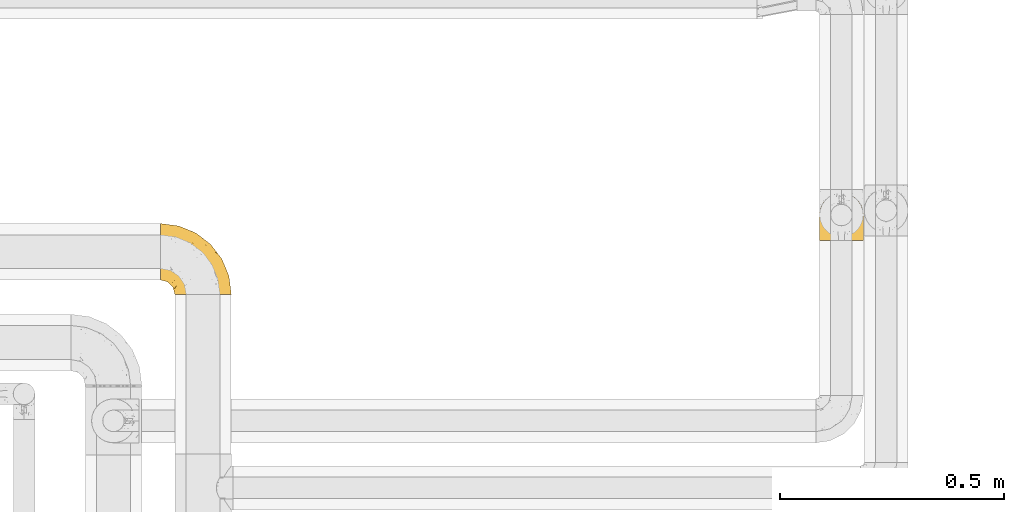
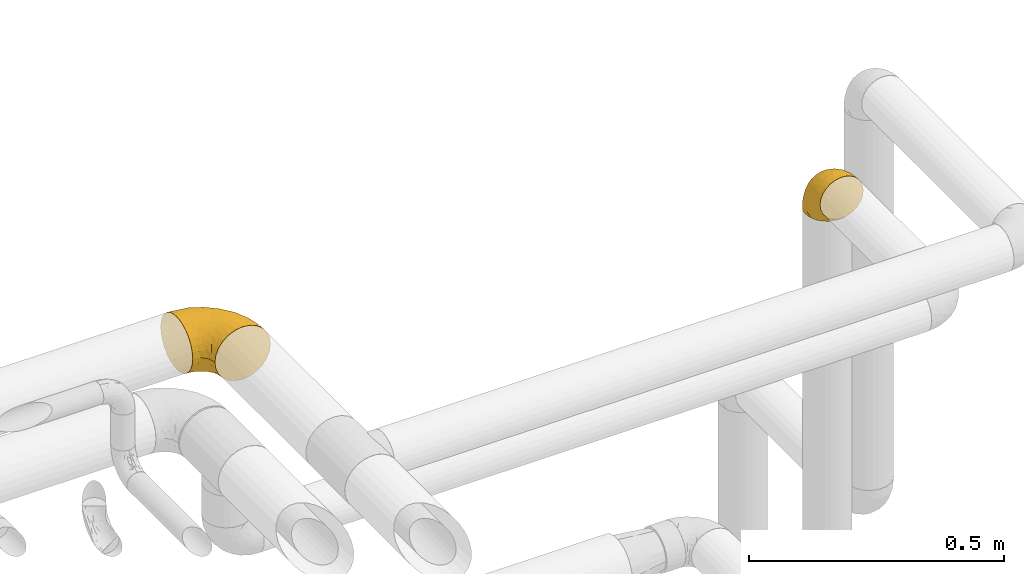
# One storey, part 414 of 827: 2 coverings.
"""IFC2X3 building model written with IfcOpenShell, lengths in millimetres."""

from ifc_helpers import new_model, entity, si_unit, converted_unit, derived_unit, direction, frame, origin, place, context, subcontext, project, spatial, faceted_brep, element, save


model = new_model("IFC2X3")

# Units and contexts
model_context = context("Model", 3, precision=0.01, world=origin(), true_north=direction((6.12303176911189e-17, 1.0)))
body_context = subcontext(model_context, "Body", "Model", "MODEL_VIEW")
ifc_project = project(units=[si_unit("LENGTHUNIT", "METRE", prefix="MILLI"), si_unit("AREAUNIT", "SQUARE_METRE"), si_unit("VOLUMEUNIT", "CUBIC_METRE"), converted_unit("PLANEANGLEUNIT", "DEGREE", entity("IfcRatioMeasure", 0.0174532925199433), si_unit("PLANEANGLEUNIT", "RADIAN"), dimensions=[0, 0, 0, 0, 0, 0, 0]), si_unit("MASSUNIT", "GRAM", prefix="KILO"), derived_unit("MASSDENSITYUNIT", [(si_unit("MASSUNIT", "GRAM", prefix="KILO"), 1), (si_unit("LENGTHUNIT", "METRE"), -3)]), derived_unit("MOMENTOFINERTIAUNIT", [(si_unit("LENGTHUNIT", "METRE"), 4)]), si_unit("TIMEUNIT", "SECOND"), si_unit("FREQUENCYUNIT", "HERTZ"), si_unit("THERMODYNAMICTEMPERATUREUNIT", "DEGREE_CELSIUS"), derived_unit("THERMALTRANSMITTANCEUNIT", [(si_unit("MASSUNIT", "GRAM", prefix="KILO"), 1), (si_unit("THERMODYNAMICTEMPERATUREUNIT", "KELVIN"), -1), (si_unit("TIMEUNIT", "SECOND"), -3)]), derived_unit("VOLUMETRICFLOWRATEUNIT", [(si_unit("LENGTHUNIT", "METRE"), 3), (si_unit("TIMEUNIT", "SECOND"), -1)]), derived_unit("MASSFLOWRATEUNIT", [(si_unit("MASSUNIT", "GRAM", prefix="KILO"), 1), (si_unit("TIMEUNIT", "SECOND"), -1)]), derived_unit("ROTATIONALFREQUENCYUNIT", [(si_unit("TIMEUNIT", "SECOND"), -1)]), si_unit("ELECTRICCURRENTUNIT", "AMPERE"), si_unit("ELECTRICVOLTAGEUNIT", "VOLT"), si_unit("POWERUNIT", "WATT"), si_unit("FORCEUNIT", "NEWTON", prefix="KILO"), si_unit("ILLUMINANCEUNIT", "LUX"), si_unit("LUMINOUSFLUXUNIT", "LUMEN"), si_unit("LUMINOUSINTENSITYUNIT", "CANDELA"), derived_unit("USERDEFINED", [(si_unit("MASSUNIT", "GRAM", prefix="KILO"), -1), (si_unit("LENGTHUNIT", "METRE"), -2), (si_unit("TIMEUNIT", "SECOND"), 3), (si_unit("LUMINOUSFLUXUNIT", "LUMEN"), 1)]), derived_unit("LINEARVELOCITYUNIT", [(si_unit("LENGTHUNIT", "METRE"), 1), (si_unit("TIMEUNIT", "SECOND"), -1)]), si_unit("PRESSUREUNIT", "PASCAL"), derived_unit("USERDEFINED", [(si_unit("LENGTHUNIT", "METRE"), -2), (si_unit("MASSUNIT", "GRAM", prefix="KILO"), 1), (si_unit("TIMEUNIT", "SECOND"), -2)]), derived_unit("LINEARFORCEUNIT", [(si_unit("MASSUNIT", "GRAM", prefix="KILO"), 1), (si_unit("LENGTHUNIT", "METRE"), 1), (si_unit("TIMEUNIT", "SECOND"), -2), (si_unit("LENGTHUNIT", "METRE"), -1)]), derived_unit("PLANARFORCEUNIT", [(si_unit("MASSUNIT", "GRAM", prefix="KILO"), 1), (si_unit("LENGTHUNIT", "METRE"), 1), (si_unit("TIMEUNIT", "SECOND"), -2), (si_unit("LENGTHUNIT", "METRE"), -2)])], contexts=[model_context])

# Site, building, storey
site_placement = place(None, origin())
site = spatial("IfcSite", under=ifc_project, at=site_placement, CompositionType="ELEMENT")
building_placement = place(site_placement, origin())
building = spatial("IfcBuilding", under=site, at=building_placement, CompositionType="ELEMENT")
storey_placement = place(building_placement, frame((0.0, 0.0, 28200.0)))
storey = spatial("IfcBuildingStorey", under=building, at=storey_placement, Name="08", CompositionType="ELEMENT", Elevation=28200.0)

# Coverings
covering_1_placement = place(storey_placement, frame((48748.44, 18461.91, 2935.35)))
element("IfcCovering", 1, at=covering_1_placement, inside=storey, Name=":ADSK_", ObjectType=":ADSK_", PredefinedType="INSULATION", context=body_context, shape_type="Brep", body=[
    faceted_brep([(1.6, 110.62, 126.11), (1.6, 123.95, 121.45), (1.6, 135.9, 113.94), (1.6, 145.89, 103.96), (1.6, 153.4, 92.0), (1.6, 158.06, 78.68), (1.6, 159.65, 64.65), (1.6, 158.06, 50.62), (1.6, 153.4, 37.29), (1.6, 145.89, 25.34), (1.6, 135.91, 15.35), (1.6, 123.95, 7.84), (1.6, 110.63, 3.18), (1.6, 96.6, 1.6), (1.6, 82.57, 3.18), (1.6, 69.24, 7.84), (1.6, 57.29, 15.35), (1.6, 47.3, 25.33), (1.6, 39.79, 37.29), (1.6, 35.13, 50.61), (1.6, 33.55, 64.65), (1.6, 35.13, 78.67), (1.6, 39.79, 92.0), (1.6, 47.3, 103.95), (1.6, 57.28, 113.94), (1.6, 69.24, 121.45), (1.6, 82.56, 126.11), (1.6, 96.6, 127.7), (33.55, 1.6, 64.65), (35.69, 1.6, 48.33), (41.99, 1.6, 33.12), (52.01, 1.6, 20.06), (65.07, 1.6, 10.04), (80.28, 1.6, 3.74), (85.89, 1.6, 3.01), (96.6, 1.6, 1.6), (112.91, 1.6, 3.74), (128.12, 1.6, 10.04), (141.18, 1.6, 20.06), (151.2, 1.6, 33.12), (157.5, 1.6, 48.33), (159.65, 1.6, 64.65), (157.5, 1.6, 80.96), (151.2, 1.6, 96.17), (141.18, 1.6, 109.23), (128.12, 1.6, 119.25), (112.91, 1.6, 125.55), (96.6, 1.6, 127.7), (85.89, 1.6, 126.29), (80.28, 1.6, 125.55), (65.07, 1.6, 119.25), (52.01, 1.6, 109.23), (41.99, 1.6, 96.17), (35.69, 1.6, 80.96), (145.23, 30.13, 101.1), (150.95, 39.4, 86.72), (136.48, 62.65, 98.7), (156.3, 28.52, 75.93), (154.26, 42.5, 64.65), (73.92, 115.57, 113.39), (98.94, 98.94, 111.06), (102.72, 111.29, 96.87), (124.89, 95.5, 84.07), (138.47, 80.62, 64.65), (113.35, 113.35, 64.65), (120.33, 43.71, 119.56), (118.42, 70.76, 112.75), (103.99, 62.71, 122.85), (110.05, 33.16, 125.08), (94.6, 53.41, 126.64), (62.68, 130.65, 105.78), (66.8, 137.68, 93.81), (37.71, 146.84, 96.07), (141.12, 66.58, 87.11), (148.29, 57.7, 75.77), (132.76, 39.88, 111.99), (42.5, 154.26, 64.65), (39.36, 152.07, 83.58), (96.16, 125.54, 80.96), (69.16, 142.81, 78.34), (62.71, 103.99, 122.85), (79.4, 79.4, 125.88), (88.81, 88.81, 120.97), (26.93, 104.86, 126.67), (32.13, 117.38, 122.64), (78.45, 57.43, 127.7), (85.2, 44.19, 127.7), (91.95, 30.95, 127.7), (31.66, 139.96, 107.12), (45.38, 127.03, 115.07), (118.88, 87.17, 102.81), (57.43, 78.45, 127.7), (62.69, 73.2, 127.7), (67.94, 67.94, 127.7), (13.99, 94.63, 127.7), (22.47, 93.29, 127.7), (30.95, 91.95, 127.7), (53.41, 94.6, 126.64), (44.19, 85.2, 127.7), (80.62, 138.47, 64.65), (94.63, 13.99, 127.7), (39.95, 40.46, 113.05), (33.15, 32.36, 101.81), (43.2, 28.71, 108.46), (81.77, 15.53, 126.21), (66.3, 29.06, 122.65), (75.23, 40.03, 126.55), (66.55, 45.36, 125.45), (78.18, 26.46, 126.01), (56.85, 47.56, 123.3), (54.23, 36.28, 118.99), (12.94, 55.57, 113.51), (17.42, 45.02, 104.6), (27.05, 57.55, 118.04), (44.37, 11.56, 101.6), (49.66, 19.2, 109.98), (38.88, 10.07, 92.1), (37.08, 21.04, 96.28), (66.96, 15.52, 121.05), (32.99, 13.84, 79.4), (14.52, 32.67, 79.19), (26.32, 24.86, 80.39), (22.37, 34.31, 93.14), (27.96, 81.47, 126.75), (39.47, 71.26, 125.71), (15.41, 81.64, 126.17), (17.57, 29.26, 64.65), (21.32, 70.65, 123.28), (7.61, 31.93, 64.65), (28.92, 27.99, 91.58), (28.65, 41.71, 107.1), (34.82, 50.14, 116.28), (58.27, 17.57, 116.32), (11.73, 37.62, 90.34), (40.36, 60.48, 122.74), (29.26, 17.57, 64.65), (65.12, 56.96, 126.77), (45.4, 48.98, 119.84), (53.05, 57.29, 124.71), (50.39, 68.25, 126.47), (38.88, 10.07, 37.19), (42.9, 16.58, 27.66), (32.99, 13.84, 49.9), (94.63, 13.99, 1.6), (14.52, 32.67, 50.1), (26.32, 24.86, 48.89), (50.51, 67.81, 2.88), (39.41, 61.09, 6.55), (39.47, 71.26, 3.58), (78.45, 57.43, 1.6), (85.2, 44.19, 1.6), (75.23, 40.03, 2.74), (27.05, 57.55, 11.25), (36.34, 51.01, 11.93), (28.89, 42.79, 21.09), (78.18, 26.46, 3.28), (66.3, 29.06, 6.64), (58.27, 17.57, 12.97), (49.66, 19.2, 19.31), (39.95, 40.46, 16.23), (42.42, 28.84, 21.44), (32.56, 33.48, 26.96), (66.96, 15.52, 8.24), (81.77, 15.53, 3.08), (54.23, 36.28, 10.3), (11.73, 37.62, 38.95), (37.08, 21.04, 33.01), (13.99, 94.63, 1.6), (22.47, 93.29, 1.6), (22.37, 34.31, 36.15), (17.42, 45.03, 24.69), (21.32, 70.65, 6.01), (27.96, 81.47, 2.54), (12.94, 55.58, 15.78), (30.95, 91.95, 1.6), (15.41, 81.64, 3.12), (29.3, 27.86, 37.33), (57.43, 78.45, 1.6), (44.19, 85.2, 1.6), (65.12, 56.96, 2.52), (66.55, 45.36, 3.84), (56.85, 47.57, 5.99), (46.41, 48.27, 9.35), (67.94, 67.94, 1.6), (53.04, 57.3, 4.58), (91.95, 30.95, 1.6), (136.48, 62.65, 30.59), (145.23, 30.13, 28.19), (132.76, 39.88, 17.3), (120.33, 43.71, 9.73), (150.95, 39.4, 42.57), (149.01, 55.79, 53.51), (156.33, 28.41, 53.42), (94.6, 53.41, 2.65), (26.93, 104.86, 2.62), (32.14, 117.39, 6.66), (62.71, 103.99, 6.44), (96.16, 125.54, 48.33), (102.72, 111.29, 32.42), (66.79, 137.69, 35.49), (53.41, 94.6, 2.65), (79.4, 79.4, 3.41), (110.05, 33.16, 4.21), (140.44, 68.78, 43.07), (62.68, 130.66, 23.52), (31.66, 139.97, 22.18), (29.31, 148.6, 33.1), (73.92, 115.58, 15.9), (45.39, 127.03, 14.23), (118.42, 70.76, 16.54), (124.89, 95.5, 45.22), (103.99, 62.71, 6.44), (88.81, 88.81, 8.33), (98.94, 98.94, 18.23), (122.85, 89.09, 32.99), (138.38, 78.72, 53.35), (69.18, 142.21, 48.76), (39.36, 152.07, 45.72)], [[[0, 1, 2, 3, 4, 5, 6, 7, 8, 9, 10, 11, 12, 13, 14, 15, 16, 17, 18, 19, 20, 21, 22, 23, 24, 25, 26, 27]], [[28, 29, 30, 31, 32, 33, 34, 35, 36, 37, 38, 39, 40, 41, 42, 43, 44, 45, 46, 47, 48, 49, 50, 51, 52, 53]], [[54, 55, 56]], [[57, 41, 58]], [[59, 60, 61]], [[62, 63, 64]], [[65, 66, 67]], [[68, 67, 69]], [[70, 71, 72]], [[55, 73, 56]], [[43, 42, 55]], [[55, 74, 73]], [[44, 75, 45]], [[44, 43, 54]], [[76, 5, 77]], [[71, 78, 79]], [[45, 75, 65]], [[46, 68, 47]], [[80, 81, 82]], [[0, 83, 84]], [[69, 85, 86, 87]], [[69, 81, 85]], [[84, 1, 0]], [[2, 88, 3]], [[4, 3, 72]], [[44, 54, 75]], [[5, 4, 77]], [[89, 2, 1]], [[72, 3, 88]], [[5, 76, 6]], [[70, 88, 89]], [[68, 65, 67]], [[88, 2, 89]], [[56, 90, 66]], [[64, 78, 62]], [[81, 91, 92, 93, 85]], [[83, 27, 94, 95, 96]], [[62, 61, 90]], [[97, 96, 98, 91]], [[80, 97, 81]], [[42, 57, 55]], [[62, 78, 61]], [[84, 89, 1]], [[78, 64, 99]], [[57, 74, 55]], [[76, 77, 79]], [[77, 72, 71]], [[82, 81, 67]], [[97, 83, 96]], [[80, 89, 84]], [[79, 78, 99]], [[71, 70, 61]], [[81, 97, 91]], [[83, 80, 84]], [[68, 87, 100, 47]], [[81, 69, 67]], [[68, 69, 87]], [[65, 46, 45]], [[65, 68, 46]], [[66, 65, 75]], [[56, 66, 75]], [[66, 60, 82]], [[71, 61, 78]], [[60, 66, 90]], [[83, 97, 80]], [[27, 83, 0]], [[59, 70, 89]], [[70, 59, 61]], [[89, 80, 59]], [[82, 59, 80]], [[55, 54, 43]], [[75, 54, 56]], [[66, 82, 67]], [[59, 82, 60]], [[41, 57, 42]], [[74, 57, 58]], [[58, 63, 74]], [[62, 74, 63]], [[74, 62, 73]], [[62, 56, 73]], [[4, 72, 77]], [[70, 72, 88]], [[76, 79, 99]], [[71, 79, 77]], [[62, 90, 56]], [[60, 90, 61]], [[101, 102, 103]], [[100, 87, 104]], [[105, 106, 107]], [[108, 104, 87]], [[107, 109, 110]], [[108, 87, 86]], [[111, 112, 113]], [[114, 51, 115]], [[116, 114, 117]], [[51, 50, 118]], [[119, 28, 53]], [[120, 121, 122]], [[98, 123, 124]], [[125, 96, 95]], [[116, 53, 52]], [[126, 121, 120]], [[104, 108, 118]], [[98, 124, 91]], [[25, 24, 127]], [[120, 128, 126]], [[122, 129, 102]], [[95, 94, 27, 26]], [[122, 102, 130]], [[125, 127, 123]], [[24, 111, 127]], [[21, 20, 128]], [[112, 130, 131]], [[48, 47, 100, 49]], [[132, 110, 115]], [[23, 111, 24]], [[129, 119, 117]], [[120, 133, 21]], [[112, 23, 22]], [[134, 113, 131]], [[121, 126, 135]], [[133, 112, 22]], [[128, 120, 21]], [[132, 51, 118]], [[120, 122, 133]], [[119, 121, 135]], [[129, 117, 102]], [[125, 26, 25]], [[26, 125, 95]], [[127, 125, 25]], [[28, 119, 135]], [[119, 53, 116]], [[127, 113, 124]], [[96, 125, 123]], [[112, 131, 113]], [[101, 103, 110]], [[85, 93, 136]], [[124, 123, 127]], [[98, 96, 123]], [[112, 111, 23]], [[127, 111, 113]], [[112, 133, 122]], [[21, 133, 22]], [[107, 110, 105]], [[110, 109, 137]], [[86, 106, 108]], [[138, 109, 136]], [[105, 118, 108]], [[107, 106, 85]], [[104, 50, 49]], [[124, 134, 139]], [[138, 93, 92]], [[92, 91, 139]], [[100, 104, 49]], [[118, 105, 132]], [[104, 118, 50]], [[110, 132, 105]], [[51, 132, 115]], [[108, 106, 105]], [[85, 106, 86]], [[114, 116, 52]], [[119, 116, 117]], [[51, 114, 52]], [[114, 115, 103]], [[117, 114, 103]], [[130, 102, 101]], [[117, 103, 102]], [[110, 103, 115]], [[130, 101, 131]], [[122, 130, 112]], [[101, 137, 131]], [[113, 134, 124]], [[137, 134, 131]], [[124, 139, 91]], [[134, 138, 139]], [[92, 139, 138]], [[110, 137, 101]], [[134, 137, 138]], [[136, 109, 107]], [[137, 109, 138]], [[85, 136, 107]], [[138, 136, 93]], [[122, 121, 129]], [[129, 121, 119]], [[30, 140, 141]], [[30, 29, 140]], [[28, 135, 142]], [[143, 35, 34, 33]], [[19, 144, 128]], [[126, 145, 135]], [[146, 147, 148]], [[149, 150, 151]], [[152, 153, 154]], [[155, 156, 151]], [[157, 31, 158]], [[159, 160, 161]], [[32, 162, 163]], [[158, 31, 30]], [[157, 164, 156]], [[126, 144, 145]], [[126, 128, 144]], [[18, 165, 19]], [[141, 166, 160]], [[14, 13, 167, 168]], [[163, 143, 33]], [[169, 165, 170]], [[18, 17, 170]], [[153, 159, 154]], [[142, 135, 145]], [[148, 171, 172]], [[159, 161, 154]], [[171, 152, 173]], [[173, 17, 16]], [[16, 15, 171]], [[158, 160, 164]], [[174, 175, 168]], [[173, 170, 17]], [[19, 128, 20]], [[174, 172, 175]], [[165, 169, 144]], [[162, 157, 156]], [[175, 172, 171]], [[144, 169, 145]], [[176, 169, 161]], [[166, 140, 142]], [[175, 171, 15]], [[168, 175, 14]], [[14, 175, 15]], [[142, 145, 176]], [[28, 142, 29]], [[148, 177, 146]], [[148, 178, 177]], [[152, 171, 148]], [[179, 180, 181]], [[164, 180, 156]], [[174, 178, 172]], [[148, 172, 178]], [[171, 173, 16]], [[170, 173, 152]], [[19, 165, 144]], [[170, 165, 18]], [[153, 182, 159]], [[146, 183, 184]], [[181, 180, 164]], [[180, 151, 156]], [[163, 155, 185]], [[155, 150, 185]], [[162, 156, 155]], [[143, 163, 185]], [[180, 179, 149]], [[32, 163, 33]], [[163, 162, 155]], [[31, 162, 32]], [[31, 157, 162]], [[164, 157, 158]], [[149, 151, 180]], [[155, 151, 150]], [[142, 140, 29]], [[141, 140, 166]], [[176, 145, 169]], [[30, 141, 158]], [[164, 160, 159]], [[158, 141, 160]], [[166, 161, 160]], [[154, 169, 170]], [[169, 154, 161]], [[152, 154, 170]], [[147, 152, 148]], [[153, 147, 182]], [[181, 182, 184]], [[164, 159, 182]], [[161, 166, 176]], [[142, 176, 166]], [[183, 146, 177]], [[184, 182, 147]], [[184, 147, 146]], [[152, 147, 153]], [[182, 181, 164]], [[179, 184, 183]], [[184, 179, 181]], [[149, 179, 183]], [[186, 187, 188]], [[37, 36, 189]], [[190, 191, 192]], [[193, 185, 150, 149]], [[194, 195, 196]], [[197, 198, 199]], [[200, 201, 177]], [[193, 202, 185]], [[203, 190, 186]], [[202, 189, 36]], [[41, 40, 192]], [[204, 205, 199]], [[9, 8, 206]], [[187, 190, 39]], [[40, 39, 190]], [[38, 37, 188]], [[207, 208, 204]], [[202, 35, 143, 185]], [[39, 38, 187]], [[195, 11, 208]], [[201, 149, 183, 177]], [[188, 189, 209]], [[197, 64, 210]], [[186, 188, 209]], [[13, 12, 194]], [[211, 201, 212]], [[12, 11, 195]], [[193, 201, 211]], [[212, 201, 196]], [[10, 208, 11]], [[213, 214, 209]], [[64, 63, 215]], [[216, 197, 199]], [[8, 217, 206]], [[7, 217, 8]], [[203, 191, 190]], [[7, 6, 76]], [[208, 205, 204]], [[205, 10, 9]], [[199, 205, 206]], [[7, 76, 217]], [[205, 208, 10]], [[216, 76, 99]], [[200, 177, 178, 174]], [[64, 197, 99]], [[63, 58, 191]], [[208, 196, 195]], [[196, 200, 194]], [[198, 197, 210]], [[216, 199, 217]], [[201, 193, 149]], [[202, 193, 211]], [[202, 211, 189]], [[35, 202, 36]], [[211, 212, 209]], [[37, 189, 188]], [[211, 209, 189]], [[213, 198, 214]], [[200, 174, 194]], [[201, 200, 196]], [[214, 198, 210]], [[213, 207, 198]], [[194, 174, 168, 167, 13]], [[195, 194, 12]], [[198, 204, 199]], [[204, 198, 207]], [[212, 207, 213]], [[196, 208, 207]], [[188, 187, 38]], [[190, 187, 186]], [[207, 212, 196]], [[209, 212, 213]], [[214, 203, 186]], [[191, 215, 63]], [[191, 203, 215]], [[192, 191, 58]], [[41, 192, 58]], [[190, 192, 40]], [[203, 210, 215]], [[64, 215, 210]], [[199, 206, 217]], [[9, 206, 205]], [[76, 216, 217]], [[99, 197, 216]], [[203, 214, 210]], [[209, 214, 186]]]),
])
covering_2_placement = place(storey_placement, frame((50221.29, 18581.93, 2741.4)))
element("IfcCovering", 2, at=covering_2_placement, inside=storey, Name=":ADSK_", ObjectType=":ADSK_", PredefinedType="INSULATION", context=body_context, shape_type="Brep", body=[
    faceted_brep([(1.6, 58.6, 1.6), (2.83, 69.54, 1.6), (6.47, 79.93, 1.6), (12.32, 89.25, 1.6), (20.11, 97.03, 1.6), (29.43, 102.88, 1.6), (39.81, 106.51, 1.6), (50.75, 107.75, 1.6), (61.69, 106.51, 1.6), (72.08, 102.87, 1.6), (81.4, 97.02, 1.6), (89.18, 89.23, 1.6), (95.03, 79.91, 1.6), (98.66, 69.53, 1.6), (99.9, 58.6, 1.6), (99.25, 52.89, 1.6), (98.66, 47.65, 1.6), (96.84, 42.46, 1.6), (95.02, 37.26, 1.6), (89.17, 27.94, 1.6), (81.38, 20.16, 1.6), (72.06, 14.31, 1.6), (61.68, 10.68, 1.6), (50.75, 9.45, 1.6), (39.8, 10.68, 1.6), (29.41, 14.32, 1.6), (20.09, 20.17, 1.6), (12.31, 27.96, 1.6), (6.46, 37.28, 1.6), (4.64, 42.47, 1.6), (2.83, 47.66, 1.6), (2.24, 52.89, 1.6), (1.92, 55.75, 1.6), (63.47, 1.6, 11.12), (75.32, 1.6, 16.03), (80.41, 1.6, 19.94), (85.5, 1.6, 23.84), (89.4, 1.6, 28.93), (93.31, 1.6, 34.02), (95.77, 1.6, 39.95), (98.22, 1.6, 45.87), (99.14, 1.6, 52.86), (99.52, 1.6, 55.73), (99.9, 1.6, 58.6), (98.22, 1.6, 71.32), (93.31, 1.6, 83.17), (85.5, 1.6, 93.35), (75.32, 1.6, 101.16), (63.47, 1.6, 106.07), (50.75, 1.6, 107.75), (38.02, 1.6, 106.07), (26.17, 1.6, 101.16), (15.99, 1.6, 93.35), (8.18, 1.6, 83.17), (3.27, 1.6, 71.32), (1.6, 1.6, 58.6), (2.35, 1.6, 52.86), (3.27, 1.6, 45.87), (5.73, 1.6, 39.95), (8.18, 1.6, 34.02), (12.09, 1.6, 28.93), (15.99, 1.6, 23.84), (21.08, 1.6, 19.94), (26.17, 1.6, 16.03), (38.02, 1.6, 11.12), (50.75, 1.6, 9.45), (42.18, 69.96, 81.82), (28.42, 59.59, 84.02), (37.78, 51.96, 93.05), (50.75, 34.4, 102.55), (42.85, 23.37, 104.83), (50.75, 13.68, 105.83), (24.75, 41.52, 91.87), (33.81, 26.26, 101.74), (22.57, 20.18, 97.07), (7.18, 72.33, 38.45), (2.73, 65.88, 22.17), (3.09, 57.55, 42.04), (6.92, 23.76, 77.69), (11.58, 46.5, 75.76), (5.17, 46.57, 62.11), (2.71, 21.17, 66.08), (1.6, 23.41, 54.26), (1.6, 17.92, 55.35), (1.6, 12.43, 56.44), (1.6, 9.72, 56.98), (1.6, 7.01, 57.52), (14.18, 26.77, 87.84), (5.88, 76.59, 19.41), (41.06, 95.55, 48.89), (36.25, 102.57, 26.34), (28.62, 92.89, 44.55), (1.6, 54.26, 23.41), (1.6, 51.17, 28.03), (1.6, 48.08, 32.65), (1.6, 44.99, 37.28), (1.6, 41.9, 41.9), (10.85, 85.16, 20.6), (38.35, 85.97, 63.36), (9.6, 59.58, 62.21), (26.24, 99.5, 19.94), (50.75, 105.83, 13.68), (19.31, 53.59, 80.85), (16.41, 67.0, 66.53), (24.56, 71.56, 71.06), (50.75, 87.47, 63.99), (50.75, 75.73, 75.73), (18.47, 92.24, 26.77), (1.6, 58.06, 4.31), (1.6, 57.52, 7.01), (1.6, 56.44, 12.43), (1.6, 55.35, 17.92), (14.36, 81.33, 43.43), (20.64, 80.35, 56.23), (2.32, 39.44, 54.97), (50.75, 102.55, 34.4), (1.6, 37.28, 44.99), (1.6, 32.65, 48.08), (1.6, 28.03, 51.17), (50.75, 63.99, 87.47), (33.88, 74.55, 74.55), (29.24, 83.62, 60.86), (50.75, 95.01, 49.19), (50.75, 49.19, 95.01), (2.8, 46.96, 10.27), (2.48, 8.77, 48.79), (2.7, 18.28, 45.16), (3.2, 11.68, 44.99), (32.98, 11.79, 6.17), (24.67, 15.69, 7.65), (2.95, 42.49, 21.59), (2.19, 47.41, 19.96), (17.92, 7.94, 21.0), (12.02, 9.27, 27.2), (25.73, 7.98, 14.83), (16.63, 13.4, 19.7), (25.6, 13.04, 10.93), (36.72, 7.36, 9.63), (10.66, 23.46, 19.97), (6.87, 30.46, 21.13), (11.12, 26.54, 14.14), (10.31, 6.76, 30.2), (12.84, 26.46, 8.12), (17.38, 20.77, 9.93), (9.74, 20.68, 24.62), (4.63, 40.26, 11.87), (50.75, 7.15, 7.15), (42.52, 9.28, 5.32), (3.12, 38.78, 26.68), (17.58, 18.27, 13.92), (3.97, 31.78, 30.67), (5.94, 12.75, 36.65), (2.73, 22.96, 42.89), (6.23, 17.55, 34.04), (3.45, 27.63, 36.6), (10.84, 15.23, 26.41), (7.98, 33.25, 10.07), (7.33, 32.43, 15.83), (2.39, 27.9, 41.99), (75.76, 7.97, 14.83), (90.65, 15.22, 26.4), (83.57, 7.93, 21.01), (84.85, 13.38, 19.71), (71.05, 13.12, 5.72), (98.54, 42.49, 21.6), (99.3, 47.4, 19.96), (99.9, 51.17, 28.03), (96.86, 40.24, 11.87), (84.1, 20.76, 9.93), (99.9, 12.43, 56.44), (99.9, 7.01, 57.52), (99.9, 4.31, 58.06), (88.63, 26.44, 8.13), (90.36, 26.52, 14.15), (98.29, 11.68, 44.99), (95.55, 12.75, 36.65), (89.47, 9.27, 27.21), (95.26, 17.55, 34.04), (91.18, 6.76, 30.2), (93.49, 33.21, 10.06), (94.15, 32.41, 15.83), (99.01, 8.77, 48.79), (98.76, 22.96, 42.89), (98.85, 18.48, 45.38), (99.9, 56.44, 12.43), (98.69, 46.95, 10.28), (64.78, 7.36, 9.64), (99.9, 17.92, 55.35), (99.9, 23.41, 54.26), (62.91, 9.85, 6.05), (99.9, 57.52, 7.01), (99.9, 56.98, 9.72), (99.9, 48.08, 32.65), (98.37, 38.78, 26.68), (83.9, 18.25, 13.92), (99.9, 44.99, 37.28), (97.51, 31.74, 30.66), (94.62, 30.45, 21.14), (98.04, 27.63, 36.59), (91.73, 20.65, 24.6), (99.9, 55.35, 17.92), (99.9, 54.26, 23.41), (75.87, 13.03, 10.93), (90.83, 23.44, 19.97), (99.1, 27.9, 41.99), (99.9, 32.65, 48.08), (99.9, 28.03, 51.17), (99.9, 37.28, 44.99), (99.9, 41.9, 41.9), (99.09, 39.74, 55.26), (58.64, 23.37, 104.83), (87.31, 26.77, 87.84), (89.93, 46.18, 75.91), (82.22, 53.54, 80.84), (76.74, 41.53, 91.87), (73.12, 59.61, 83.98), (95.54, 76.79, 19.16), (98.7, 66.11, 22.37), (98.79, 21.17, 66.08), (63.71, 51.96, 93.05), (67.68, 26.26, 101.74), (78.92, 20.18, 97.07), (94.57, 23.76, 77.69), (72.88, 92.88, 44.55), (65.25, 102.57, 26.34), (60.44, 95.54, 48.9), (76.94, 71.63, 70.99), (67.61, 74.55, 74.55), (94.38, 72.51, 37.8), (59.31, 69.96, 81.82), (83.03, 92.23, 26.77), (90.66, 85.15, 20.6), (80.8, 80.45, 56.15), (72.22, 83.65, 60.85), (98.39, 57.57, 42.06), (92.31, 63.68, 57.03), (63.11, 85.95, 63.4), (75.27, 99.49, 19.94), (87.15, 81.23, 43.59), (96.03, 47.07, 62.61), (85.1, 66.99, 66.52)], [[[0, 1, 2, 3, 4, 5, 6, 7, 8, 9, 10, 11, 12, 13, 14, 15, 16, 17, 18, 19, 20, 21, 22, 23, 24, 25, 26, 27, 28, 29, 30, 31, 32]], [[33, 34, 35, 36, 37, 38, 39, 40, 41, 42, 43, 44, 45, 46, 47, 48, 49, 50, 51, 52, 53, 54, 55, 56, 57, 58, 59, 60, 61, 62, 63, 64, 65]], [[66, 67, 68]], [[69, 70, 71]], [[68, 72, 73]], [[73, 72, 74]], [[75, 76, 77]], [[78, 79, 80]], [[51, 50, 73]], [[81, 82, 83, 84, 85, 86, 55]], [[52, 87, 53]], [[74, 52, 51]], [[2, 1, 88]], [[89, 90, 91]], [[77, 92, 93, 94, 95, 96]], [[55, 54, 81]], [[78, 53, 87]], [[5, 90, 6]], [[88, 76, 75]], [[97, 3, 2]], [[89, 91, 98]], [[99, 80, 79]], [[90, 5, 100]], [[74, 87, 52]], [[100, 5, 4]], [[90, 101, 6]], [[79, 102, 103]], [[102, 67, 104]], [[105, 98, 106]], [[107, 4, 3]], [[76, 0, 108, 109, 110, 111, 92]], [[107, 112, 113]], [[114, 77, 96]], [[89, 115, 90]], [[114, 96, 116, 117, 118, 82]], [[75, 97, 88]], [[119, 66, 68]], [[50, 71, 70]], [[100, 91, 90]], [[99, 77, 80]], [[102, 104, 103]], [[97, 107, 3]], [[80, 81, 78]], [[107, 97, 112]], [[68, 73, 70]], [[66, 98, 120]], [[78, 81, 54]], [[114, 81, 80]], [[53, 78, 54]], [[78, 87, 79]], [[102, 87, 72]], [[79, 103, 99]], [[4, 107, 100]], [[91, 100, 107]], [[88, 97, 2]], [[112, 97, 75]], [[99, 112, 75]], [[103, 104, 113]], [[91, 121, 98]], [[89, 105, 122, 115]], [[101, 90, 115]], [[101, 7, 6]], [[88, 1, 76]], [[0, 76, 1]], [[92, 77, 76]], [[73, 74, 51]], [[87, 74, 72]], [[81, 114, 82]], [[77, 114, 80]], [[87, 102, 79]], [[67, 102, 72]], [[68, 67, 72]], [[67, 120, 104]], [[120, 121, 104]], [[104, 121, 113]], [[121, 120, 98]], [[91, 107, 113]], [[91, 113, 121]], [[103, 113, 112]], [[106, 98, 66]], [[105, 89, 98]], [[106, 66, 119]], [[67, 66, 120]], [[68, 69, 123, 119]], [[50, 49, 71]], [[50, 70, 73]], [[112, 99, 103]], [[77, 99, 75]], [[69, 68, 70]], [[29, 124, 110]], [[84, 83, 125]], [[126, 82, 118]], [[59, 58, 127]], [[25, 128, 129]], [[130, 93, 131]], [[132, 62, 133]], [[134, 135, 136]], [[137, 65, 64]], [[64, 134, 137]], [[138, 139, 140]], [[111, 110, 124, 92]], [[134, 136, 137]], [[134, 64, 63]], [[141, 61, 60]], [[125, 58, 57]], [[142, 143, 140]], [[142, 26, 143]], [[127, 83, 82]], [[28, 124, 29]], [[108, 0, 32, 31, 30, 110, 109]], [[30, 29, 110]], [[135, 144, 138]], [[28, 145, 124]], [[57, 56, 55, 86, 85, 84]], [[146, 147, 23]], [[24, 23, 147]], [[25, 143, 26]], [[95, 94, 148]], [[24, 128, 25]], [[149, 138, 143]], [[124, 145, 131]], [[127, 58, 125]], [[150, 148, 139]], [[127, 126, 151]], [[151, 59, 127]], [[152, 151, 126]], [[153, 154, 155]], [[153, 133, 141]], [[145, 28, 27]], [[142, 156, 27]], [[157, 148, 130]], [[61, 133, 62]], [[134, 132, 135]], [[147, 128, 24]], [[65, 137, 146]], [[146, 137, 147]], [[128, 137, 136]], [[137, 128, 147]], [[128, 136, 129]], [[149, 129, 136]], [[25, 129, 143]], [[158, 152, 117]], [[152, 118, 117]], [[153, 151, 152]], [[158, 116, 154]], [[144, 150, 138]], [[153, 152, 158]], [[133, 153, 155]], [[133, 155, 132]], [[60, 151, 141]], [[135, 132, 155]], [[134, 63, 132]], [[144, 135, 155]], [[135, 138, 149]], [[155, 154, 144]], [[150, 154, 96]], [[154, 150, 144]], [[148, 94, 130]], [[82, 126, 127]], [[118, 152, 126]], [[150, 96, 95]], [[139, 148, 157]], [[150, 95, 148]], [[93, 92, 131]], [[130, 145, 156]], [[130, 94, 93]], [[84, 125, 57]], [[127, 125, 83]], [[140, 139, 157]], [[150, 139, 138]], [[140, 157, 142]], [[138, 140, 143]], [[156, 142, 157]], [[27, 26, 142]], [[130, 156, 157]], [[145, 27, 156]], [[132, 63, 62]], [[124, 131, 92]], [[130, 131, 145]], [[129, 149, 143]], [[135, 149, 136]], [[141, 133, 61]], [[60, 59, 151]], [[141, 151, 153]], [[116, 96, 154]], [[153, 158, 154]], [[158, 117, 116]], [[34, 33, 159]], [[160, 161, 162]], [[22, 21, 163]], [[164, 165, 166]], [[19, 18, 167]], [[168, 21, 20]], [[42, 41, 40, 169, 170, 171, 43]], [[172, 173, 168]], [[174, 38, 175]], [[176, 177, 178]], [[179, 164, 180]], [[40, 181, 169]], [[182, 183, 175]], [[17, 184, 185]], [[65, 146, 186]], [[187, 174, 188]], [[23, 22, 189]], [[174, 39, 38]], [[15, 14, 190, 191, 184, 16]], [[181, 40, 39]], [[192, 193, 164]], [[194, 163, 168]], [[33, 186, 159]], [[180, 173, 172]], [[195, 196, 193]], [[18, 185, 167]], [[173, 180, 197]], [[198, 199, 196]], [[200, 201, 185, 184]], [[184, 17, 16]], [[18, 17, 185]], [[202, 159, 186]], [[194, 168, 203]], [[189, 163, 202]], [[204, 205, 182]], [[187, 181, 174]], [[160, 177, 176]], [[206, 183, 182]], [[206, 182, 205]], [[201, 165, 185]], [[165, 164, 167]], [[172, 179, 180]], [[202, 194, 162]], [[176, 161, 160]], [[65, 186, 33]], [[163, 189, 22]], [[175, 177, 182]], [[174, 183, 188]], [[177, 198, 204]], [[199, 160, 162]], [[198, 207, 204]], [[175, 38, 37]], [[198, 177, 160]], [[178, 177, 175]], [[176, 35, 161]], [[34, 159, 161]], [[162, 161, 159]], [[202, 162, 159]], [[199, 162, 203]], [[196, 199, 203]], [[198, 160, 199]], [[193, 197, 180]], [[208, 198, 196]], [[188, 183, 206]], [[175, 183, 174]], [[193, 192, 195]], [[195, 208, 196]], [[197, 196, 203]], [[180, 164, 193]], [[168, 163, 21]], [[166, 165, 201]], [[166, 192, 164]], [[189, 202, 186]], [[186, 146, 189]], [[23, 189, 146]], [[174, 181, 39]], [[169, 181, 187]], [[196, 197, 193]], [[173, 203, 168]], [[203, 173, 197]], [[172, 168, 20]], [[20, 19, 172]], [[179, 172, 19]], [[19, 167, 179]], [[164, 179, 167]], [[35, 176, 36]], [[35, 34, 161]], [[185, 165, 167]], [[162, 194, 203]], [[163, 194, 202]], [[176, 178, 36]], [[37, 36, 178]], [[175, 37, 178]], [[177, 204, 182]], [[207, 198, 208]], [[207, 205, 204]], [[209, 188, 206, 205, 207, 208]], [[48, 210, 71]], [[211, 212, 213]], [[214, 213, 215]], [[216, 217, 13]], [[218, 43, 171, 170, 169, 187, 188]], [[219, 220, 214]], [[47, 46, 221]], [[210, 48, 220]], [[211, 222, 212]], [[222, 45, 44]], [[221, 220, 47]], [[47, 220, 48]], [[221, 211, 214]], [[223, 224, 225]], [[211, 46, 45]], [[226, 227, 215]], [[43, 218, 44]], [[217, 216, 228]], [[219, 215, 229]], [[14, 13, 217]], [[224, 9, 8]], [[10, 230, 11]], [[11, 231, 12]], [[232, 223, 233]], [[234, 208, 195, 192, 166, 201]], [[235, 234, 228]], [[222, 44, 218]], [[106, 229, 236]], [[224, 237, 9]], [[231, 238, 228]], [[9, 237, 10]], [[115, 224, 101]], [[239, 234, 235]], [[231, 11, 230]], [[223, 230, 237]], [[224, 8, 101]], [[223, 236, 233]], [[225, 115, 122, 105]], [[216, 12, 231]], [[209, 234, 239]], [[210, 219, 69]], [[219, 214, 215]], [[229, 119, 219]], [[209, 218, 188]], [[239, 212, 222]], [[239, 222, 218]], [[45, 222, 211]], [[235, 212, 239]], [[213, 212, 240]], [[223, 237, 224]], [[230, 10, 237]], [[238, 231, 230]], [[216, 231, 228]], [[232, 230, 223]], [[235, 238, 240]], [[115, 225, 224]], [[233, 236, 227]], [[8, 7, 101]], [[234, 209, 208]], [[218, 209, 239]], [[217, 228, 234]], [[13, 12, 216]], [[234, 201, 217]], [[217, 201, 200, 184, 191, 190, 14]], [[211, 221, 46]], [[220, 221, 214]], [[71, 210, 69]], [[71, 49, 48]], [[219, 210, 220]], [[226, 215, 213]], [[211, 213, 214]], [[226, 213, 240]], [[215, 227, 229]], [[232, 240, 238]], [[233, 227, 226]], [[232, 233, 226]], [[236, 223, 225]], [[240, 232, 226]], [[232, 238, 230]], [[225, 105, 236]], [[236, 105, 106]], [[236, 229, 227]], [[123, 69, 219, 119]], [[106, 119, 229]], [[238, 235, 228]], [[212, 235, 240]]]),
])

save(model, "model.ifc")
